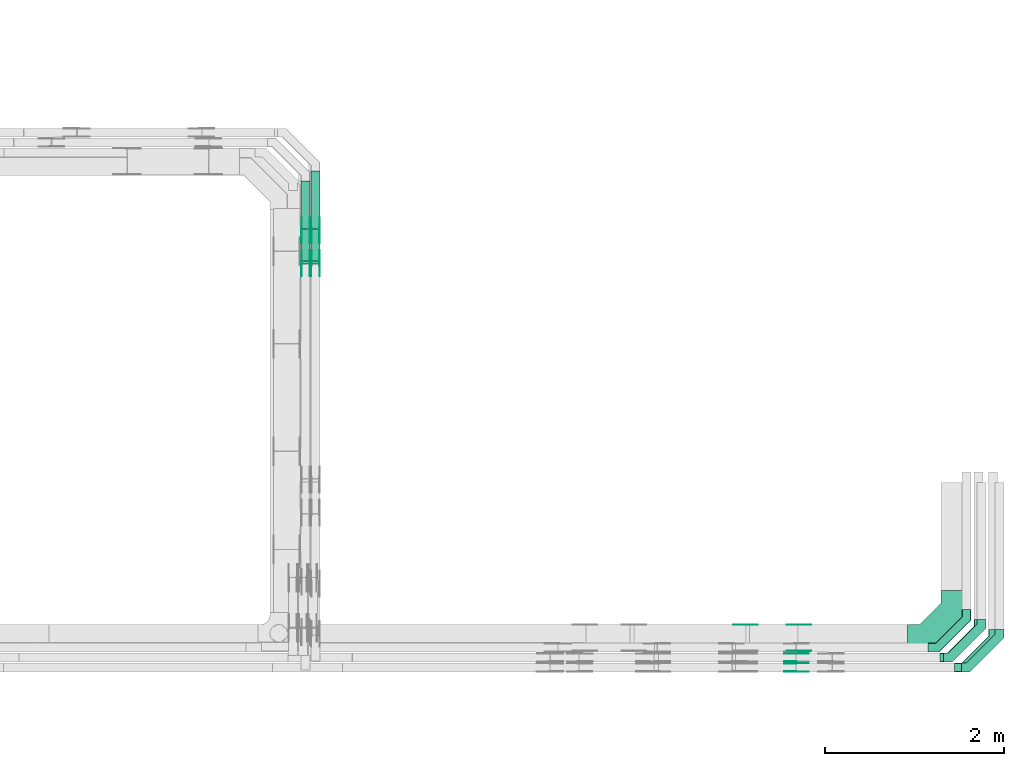
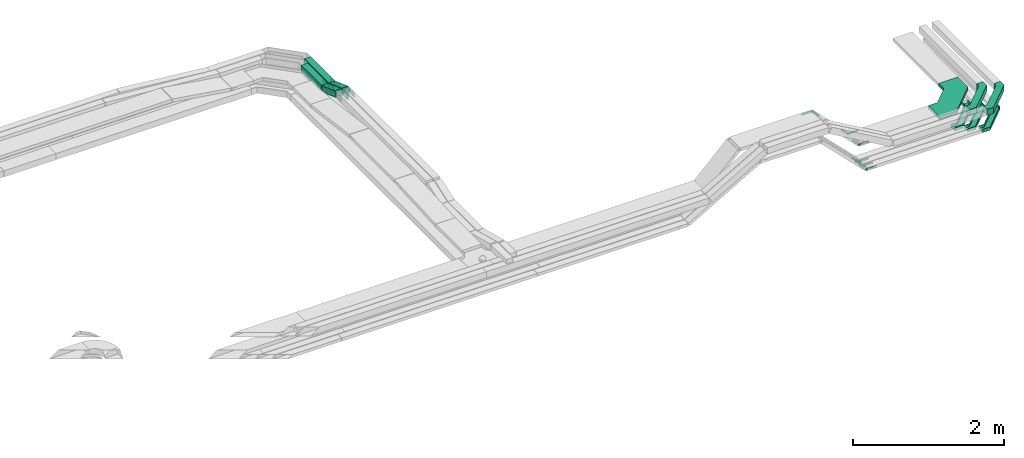
# One storey, part 27 of 33: 35 flow fittings, 4 flow segments.
"""IFC2X3 building model written with IfcOpenShell, lengths in millimetres."""

from ifc_helpers import new_model, entity, si_unit, converted_unit, derived_unit, direction, frame, frame_2d, origin, origin_2d_with_axis, place, context, subcontext, project, spatial, polyline, circle_curve, parameter, trimmed, segment, composite_curve, rectangle, outline, extrude, faceted_brep, source, transform, mapped, material, type_object, type_shapes, element, save


model = new_model("IFC2X3")

# Units and contexts
model_context = context("Model", 3, precision=0.01, world=origin(), true_north=direction((6.12303176911189e-17, 1.0)))
body_context = subcontext(model_context, "Body", "Model", "MODEL_VIEW")
ifc_project = project(units=[si_unit("LENGTHUNIT", "METRE", prefix="MILLI"), si_unit("AREAUNIT", "SQUARE_METRE"), si_unit("VOLUMEUNIT", "CUBIC_METRE"), converted_unit("PLANEANGLEUNIT", "DEGREE", entity("IfcRatioMeasure", 0.0174532925199433), si_unit("PLANEANGLEUNIT", "RADIAN"), dimensions=[0, 0, 0, 0, 0, 0, 0]), si_unit("MASSUNIT", "GRAM", prefix="KILO"), derived_unit("MASSDENSITYUNIT", [(si_unit("MASSUNIT", "GRAM", prefix="KILO"), 1), (si_unit("LENGTHUNIT", "METRE"), -3)]), derived_unit("MOMENTOFINERTIAUNIT", [(si_unit("LENGTHUNIT", "METRE"), 4)]), si_unit("TIMEUNIT", "SECOND"), si_unit("FREQUENCYUNIT", "HERTZ"), si_unit("THERMODYNAMICTEMPERATUREUNIT", "DEGREE_CELSIUS"), derived_unit("THERMALTRANSMITTANCEUNIT", [(si_unit("MASSUNIT", "GRAM", prefix="KILO"), 1), (si_unit("THERMODYNAMICTEMPERATUREUNIT", "KELVIN"), -1), (si_unit("TIMEUNIT", "SECOND"), -3)]), derived_unit("VOLUMETRICFLOWRATEUNIT", [(si_unit("LENGTHUNIT", "METRE"), 3), (si_unit("TIMEUNIT", "SECOND"), -1)]), derived_unit("MASSFLOWRATEUNIT", [(si_unit("MASSUNIT", "GRAM", prefix="KILO"), 1), (si_unit("TIMEUNIT", "SECOND"), -1)]), derived_unit("ROTATIONALFREQUENCYUNIT", [(si_unit("TIMEUNIT", "SECOND"), -1)]), si_unit("ELECTRICCURRENTUNIT", "AMPERE"), si_unit("ELECTRICVOLTAGEUNIT", "VOLT"), si_unit("POWERUNIT", "WATT"), si_unit("FORCEUNIT", "NEWTON", prefix="KILO"), si_unit("ILLUMINANCEUNIT", "LUX"), si_unit("LUMINOUSFLUXUNIT", "LUMEN"), si_unit("LUMINOUSINTENSITYUNIT", "CANDELA"), derived_unit("USERDEFINED", [(si_unit("MASSUNIT", "GRAM", prefix="KILO"), -1), (si_unit("LENGTHUNIT", "METRE"), -2), (si_unit("TIMEUNIT", "SECOND"), 3), (si_unit("LUMINOUSFLUXUNIT", "LUMEN"), 1)]), derived_unit("LINEARVELOCITYUNIT", [(si_unit("LENGTHUNIT", "METRE"), 1), (si_unit("TIMEUNIT", "SECOND"), -1)]), si_unit("PRESSUREUNIT", "PASCAL"), derived_unit("USERDEFINED", [(si_unit("LENGTHUNIT", "METRE"), -2), (si_unit("MASSUNIT", "GRAM", prefix="KILO"), 1), (si_unit("TIMEUNIT", "SECOND"), -2)]), derived_unit("LINEARFORCEUNIT", [(si_unit("MASSUNIT", "GRAM", prefix="KILO"), 1), (si_unit("LENGTHUNIT", "METRE"), 1), (si_unit("TIMEUNIT", "SECOND"), -2), (si_unit("LENGTHUNIT", "METRE"), -1)]), derived_unit("PLANARFORCEUNIT", [(si_unit("MASSUNIT", "GRAM", prefix="KILO"), 1), (si_unit("LENGTHUNIT", "METRE"), 1), (si_unit("TIMEUNIT", "SECOND"), -2), (si_unit("LENGTHUNIT", "METRE"), -2)])], contexts=[model_context])

# Site, building, storey
site_placement = place(None, frame((0.0, -0.00077364408347762, 0.0)))
site = spatial("IfcSite", under=ifc_project, at=site_placement, CompositionType="ELEMENT")
building_placement = place(site_placement, origin())
building = spatial("IfcBuilding", under=site, at=building_placement, CompositionType="ELEMENT")
storey_placement = place(building_placement, frame((0.0, 0.0, 8100.0)))
storey = spatial("IfcBuildingStorey", under=building, at=storey_placement, CompositionType="ELEMENT", Elevation=8100.0)

# Flow segments
cable_carrier_segment_type = type_object("IfcCableCarrierSegmentType", PredefinedType="CABLETRAYSEGMENT")
flow_segment_1_placement = place(storey_placement, frame((60610.1085349486, 13576.5618483229, 2715.06307654171)))
element("IfcFlowSegment", 1, at=flow_segment_1_placement, inside=storey, type_object=cable_carrier_segment_type, context=body_context, shape_type="SweptSolid", body=[
    extrude(rectangle(XDim=539.716387424886, YDim=99.9999999999946, at=origin_2d_with_axis()), frame((50.0, 269.858193712445, 0.0), z_axis=(0.0, 0.0, 1.0), x_axis=(0.0, 1.0, 0.0)), (0.0, 0.0, 1.0), 100.000000000001),
])
flow_segment_2_placement = place(storey_placement, frame((60720.1085349486, 13576.5636134989, 2715.06343817578)))
element("IfcFlowSegment", 2, at=flow_segment_2_placement, inside=storey, type_object=cable_carrier_segment_type, context=body_context, shape_type="SweptSolid", body=[
    extrude(rectangle(XDim=649.712946592026, YDim=99.9999999999946, at=frame_2d((-1.08002495835535e-12, -4.33075797445781e-12), x_axis=(1.0, 0.0))), frame((50.0, 324.859825636119, 0.0108908868867957), z_axis=(0.0, -3.35252266217634e-05, 1.0), x_axis=(0.0, 1.0, 3.35252266217634e-05)), (0.0, 0.0, 1.0), 99.9999999999995),
])
flow_segment_3_placement = place(storey_placement, frame((60610.1085349486, 13187.916855974, 2721.67706412331)))
element("IfcFlowSegment", 3, at=flow_segment_3_placement, inside=storey, type_object=cable_carrier_segment_type, context=body_context, shape_type="SweptSolid", body=[
    extrude(rectangle(XDim=99.9999999999998, YDim=99.9999999999946, at=frame_2d((0.0, -1.3926637620898e-12), x_axis=(0.0, 1.0))), frame((50.0, 17.1010071662862, 174.787393797573), z_axis=(0.0, 0.939692620785896, -0.342020143325703), x_axis=(-1.0, 0.0, 0.0)), (0.0, 0.0, 1.0), 373.670280105611),
])
flow_segment_4_placement = place(storey_placement, frame((60720.1085351478, 13187.9174212952, 2721.68065076364)))
element("IfcFlowSegment", 4, at=flow_segment_4_placement, inside=storey, type_object=cable_carrier_segment_type, context=body_context, shape_type="SweptSolid", body=[
    extrude(rectangle(XDim=99.9999996016359, YDim=99.9999996016381, at=frame_2d((0.0, -3.73034936274053e-13), x_axis=(0.0, 1.0))), frame((49.9999998008364, 17.1052008576487, 174.818569363195), z_axis=(0.0, 0.939662088474048, -0.342104018515701), x_axis=(-1.0, 0.0, 0.0)), (0.0, 0.0, 1.0), 373.674257558546),
])

# Flow fittings
ifc_material_1 = material()
cable_carrier_fitting_type_1 = type_object("IfcCableCarrierFittingType", Name="470_DKC_G5_Sheet horizontal bend:-", PredefinedType="NOTDEFINED", material=ifc_material_1)
shared_shape_1 = source(origin(), body_context, "Body", "SweptSolid", [
    extrude(outline(polyline([(-232.0, -244.0), (-135.289321881345, -244.0), (244.0, 135.289321881344), (244.0, 232.0), (144.0, 232.0), (144.0, 176.710678118654), (-176.710678118654, -144.0), (-232.0, -144.0), (-232.0, -244.0)])), frame((-194.0, 194.0, -50.0)), (0.0, 0.0, 1.0), 100.0),
])
type_shapes(cable_carrier_fitting_type_1, [shared_shape_1])
for number, where, name in (
    (5, (68397.1884624457, 8689.98005285082, 2792.0), "470_DKC_G5_Sheet horizontal bend:-"),
    (6, (68197.1884624458, 8799.97860618828, 2792.0), "470_DKC_G5_Sheet horizontal bend:-"),
):
    element("IfcFlowFitting", number, at=place(storey_placement, frame(where)), inside=storey, type_object=cable_carrier_fitting_type_1, material=ifc_material_1, Name=name, ObjectType="470_DKC_G5_Sheet horizontal bend:-", context=body_context, shape_type="MappedRepresentation", body=[
        mapped(shared_shape_1, transform((0.0, 0.0, 0.0), scale=1.0)),
    ])
cable_carrier_fitting_type_2 = type_object("IfcCableCarrierFittingType", Name="470_DKC_G5_Sheet horizontal bend:-", PredefinedType="NOTDEFINED", material=ifc_material_1)
shared_shape_2 = source(origin(), body_context, "Body", "SweptSolid", [
    extrude(outline(polyline([(-313.25, -362.749999999999), (-50.1179656440352, -362.749999999999), (362.749999999999, 50.1179656440355), (362.75, 313.249999999999), (62.7499999999997, 313.249999999999), (62.7499999999996, 174.382034355964), (-174.382034355964, -62.7499999999997), (-313.25, -62.7499999999996), (-313.25, -362.749999999999)])), frame((-212.749999999993, 212.749999999989, -25.0)), (0.0, 0.0, 1.0), 50.0000000000003),
])
type_shapes(cable_carrier_fitting_type_2, [shared_shape_2])
flow_fitting_placement = place(storey_placement, frame((67897.1884624458, 9019.97860618827, 2767.0)))
element("IfcFlowFitting", 7, at=flow_fitting_placement, inside=storey, type_object=cable_carrier_fitting_type_2, material=ifc_material_1, Name="470_DKC_G5_Sheet horizontal bend:-", ObjectType="470_DKC_G5_Sheet horizontal bend:-", context=body_context, shape_type="MappedRepresentation", body=[
    mapped(shared_shape_2, transform((0.0, 0.0, 0.0), scale=1.0)),
])
ifc_material_2 = material(Name="G")
cable_carrier_fitting_type_3 = type_object("IfcCableCarrierFittingType", PredefinedType="NOTDEFINED", material=ifc_material_2)
shared_shape_3 = source(origin(), body_context, "Body", "SweptSolid", [
    extrude(outline(composite_curve([segment(trimmed(circle_curve(frame_2d((-44.5901162790698, 0.0), x_axis=(1.0, 0.0)), 12.5), [parameter(90.0000000000007)], [parameter(270.0)], True, "PARAMETER"), True, "CONTINUOUS"), segment(polyline([(-44.5901162790697, -12.5), (-33.0901162790698, -12.5)]), True, "CONTINUOUS"), segment(polyline([(-33.0901162790698, -12.5), (-31.2296511627907, -14.5)]), True, "CONTINUOUS"), segment(polyline([(-31.2296511627907, -14.5), (108.90988372093, -14.5)]), True, "CONTINUOUS"), segment(polyline([(108.90988372093, -14.5), (108.90988372093, 14.5)]), True, "CONTINUOUS"), segment(polyline([(108.90988372093, 14.5), (-31.2296511627907, 14.5)]), True, "CONTINUOUS"), segment(polyline([(-31.2296511627907, 14.5), (-33.0901162790698, 12.5)]), True, "CONTINUOUS"), segment(polyline([(-33.0901162790698, 12.5), (-44.5901162790699, 12.5)]), True, "CONTINUOUS")], self_intersect=False)), frame((44.5901162790698, 0.0, 0.0), z_axis=(0.0, 0.0, -1.0), x_axis=(1.0, 0.0, 0.0)), (0.0, 0.0, -1.0), 2.0),
])
type_shapes(cable_carrier_fitting_type_3, [shared_shape_3])
for number, where, z_axis, x_axis in (
    (8, (65581.9936666899, 9165.43860619844, 3327.14825589831), (0.0, 1.0, 0.0), (0.707106781186591, 0.0, -0.707106781186504)),
    (9, (66118.4572387913, 8644.5200528406, 2514.200002718), (0.0, -1.0, 0.0), (1.0, 0.0, 0.0)),
    (10, (66142.1419225882, 8874.51860617812, 2767.0), (0.0, -1.0, 0.0), (1.0, 0.0, 0.0)),
):
    element("IfcFlowFitting", number, at=place(storey_placement, frame(where, z_axis=z_axis, x_axis=x_axis)), inside=storey, type_object=cable_carrier_fitting_type_3, material=ifc_material_2, context=body_context, shape_type="MappedRepresentation", body=[
        mapped(shared_shape_3, transform((0.0, 0.0, 0.0), scale=1.0)),
    ])
cable_carrier_fitting_type_4 = type_object("IfcCableCarrierFittingType", PredefinedType="NOTDEFINED", material=ifc_material_2)
shared_shape_4 = source(origin(), body_context, "Body", "SweptSolid", [
    extrude(outline(composite_curve([segment(trimmed(circle_curve(frame_2d((-44.5901162790697, 0.0), x_axis=(1.0, 0.0)), 12.5), [parameter(90.0000000000007)], [parameter(270.0)], True, "PARAMETER"), True, "CONTINUOUS"), segment(polyline([(-44.5901162790697, -12.5), (-33.0901162790697, -12.5)]), True, "CONTINUOUS"), segment(polyline([(-33.0901162790697, -12.5), (-31.2296511627907, -14.5)]), True, "CONTINUOUS"), segment(polyline([(-31.2296511627907, -14.5), (108.90988372093, -14.5)]), True, "CONTINUOUS"), segment(polyline([(108.90988372093, -14.5), (108.90988372093, 14.5)]), True, "CONTINUOUS"), segment(polyline([(108.90988372093, 14.5), (-31.2296511627907, 14.5)]), True, "CONTINUOUS"), segment(polyline([(-31.2296511627907, 14.5), (-33.0901162790698, 12.5)]), True, "CONTINUOUS"), segment(polyline([(-33.0901162790698, 12.5), (-44.5901162790699, 12.5)]), True, "CONTINUOUS")], self_intersect=False)), frame((44.5901162790697, 0.0, 0.0)), (0.0, 0.0, 1.0), 2.0),
])
type_shapes(cable_carrier_fitting_type_4, [shared_shape_4])
for number, where, z_axis, x_axis in (
    (11, (66118.4572387915, 8845.43860619836, 2514.20000271791), (0.0, 1.0, 0.0), (1.0, 0.0, 0.0)),
    (12, (66118.4572387913, 8735.44005286092, 2514.20000271799), (0.0, 1.0, 0.0), (1.0, 0.0, 0.0)),
    (13, (66142.1419225882, 9165.43860619843, 2767.0), (0.0, 1.0, 0.0), (1.0, 0.0, 0.0)),
):
    element("IfcFlowFitting", number, at=place(storey_placement, frame(where, z_axis=z_axis, x_axis=x_axis)), inside=storey, type_object=cable_carrier_fitting_type_4, material=ifc_material_2, context=body_context, shape_type="MappedRepresentation", body=[
        mapped(shared_shape_4, transform((0.0, 0.0, 0.0), scale=1.0)),
    ])
cable_carrier_fitting_type_5 = type_object("IfcCableCarrierFittingType", PredefinedType="NOTDEFINED", material=ifc_material_2)
shared_shape_5 = source(origin(), body_context, "Body", "SweptSolid", [
    extrude(outline(composite_curve([segment(trimmed(circle_curve(frame_2d((-44.5901162790698, 0.0), x_axis=(1.0, 0.0)), 12.5), [parameter(90.0000000000007)], [parameter(270.0)], True, "PARAMETER"), True, "CONTINUOUS"), segment(polyline([(-44.5901162790697, -12.5), (-33.0901162790698, -12.5)]), True, "CONTINUOUS"), segment(polyline([(-33.0901162790698, -12.5), (-31.2296511627907, -14.5)]), True, "CONTINUOUS"), segment(polyline([(-31.2296511627907, -14.5), (108.90988372093, -14.5)]), True, "CONTINUOUS"), segment(polyline([(108.90988372093, -14.5), (108.90988372093, 14.5)]), True, "CONTINUOUS"), segment(polyline([(108.90988372093, 14.5), (-31.2296511627907, 14.5)]), True, "CONTINUOUS"), segment(polyline([(-31.2296511627907, 14.5), (-33.0901162790698, 12.5)]), True, "CONTINUOUS"), segment(polyline([(-33.0901162790698, 12.5), (-44.5901162790699, 12.5)]), True, "CONTINUOUS")], self_intersect=False)), frame((44.5901162790698, 0.0, 0.0), z_axis=(0.0, 0.0, -1.0), x_axis=(1.0, 0.0, 0.0)), (0.0, 0.0, -1.0), 2.0),
])
type_shapes(cable_carrier_fitting_type_5, [shared_shape_5])
for number, where, z_axis, x_axis in (
    (14, (66118.4572387915, 8843.43860619836, 2514.20000271791), (0.0, 1.0, 0.0), (-0.707106781186549, 0.0, 0.707106781186547)),
    (15, (66118.4572387913, 8733.44005286092, 2514.20000271799), (0.0, 1.0, 0.0), (-0.707106781186497, 0.0, 0.707106781186598)),
    (16, (66142.1419225882, 9163.43860619843, 2767.0), (0.0, 1.0, 0.0), (-0.707106781186539, 0.0, 0.707106781186556)),
):
    element("IfcFlowFitting", number, at=place(storey_placement, frame(where, z_axis=z_axis, x_axis=x_axis)), inside=storey, type_object=cable_carrier_fitting_type_5, material=ifc_material_2, context=body_context, shape_type="MappedRepresentation", body=[
        mapped(shared_shape_5, transform((0.0, 0.0, 0.0), scale=1.0)),
    ])
cable_carrier_fitting_type_6 = type_object("IfcCableCarrierFittingType", PredefinedType="NOTDEFINED", material=ifc_material_2)
shared_shape_6 = source(origin(), body_context, "Body", "SweptSolid", [
    extrude(outline(composite_curve([segment(trimmed(circle_curve(frame_2d((-44.5901162790697, 0.0), x_axis=(1.0, 0.0)), 12.5), [parameter(90.0000000000007)], [parameter(270.0)], True, "PARAMETER"), True, "CONTINUOUS"), segment(polyline([(-44.5901162790697, -12.5), (-33.0901162790697, -12.5)]), True, "CONTINUOUS"), segment(polyline([(-33.0901162790697, -12.5), (-31.2296511627907, -14.5)]), True, "CONTINUOUS"), segment(polyline([(-31.2296511627907, -14.5), (108.90988372093, -14.5)]), True, "CONTINUOUS"), segment(polyline([(108.90988372093, -14.5), (108.90988372093, 14.5)]), True, "CONTINUOUS"), segment(polyline([(108.90988372093, 14.5), (-31.2296511627907, 14.5)]), True, "CONTINUOUS"), segment(polyline([(-31.2296511627907, 14.5), (-33.0901162790698, 12.5)]), True, "CONTINUOUS"), segment(polyline([(-33.0901162790698, 12.5), (-44.5901162790699, 12.5)]), True, "CONTINUOUS")], self_intersect=False)), frame((44.5901162790697, 0.0, 0.0)), (0.0, 0.0, 1.0), 2.0),
])
type_shapes(cable_carrier_fitting_type_6, [shared_shape_6])
for number, where, z_axis, x_axis in (
    (17, (65581.9936666899, 9163.43860619843, 3327.14825589831), (0.0, 1.0, 0.0), (-1.0, 0.0, 0.0)),
    (18, (66118.4572387915, 8756.51860617805, 2514.20000271791), (0.0, -1.0, 0.0), (-0.707106781186549, 0.0, 0.707106781186547)),
    (19, (66118.4572387913, 8646.5200528406, 2514.200002718), (0.0, -1.0, 0.0), (-0.707106781186497, 0.0, 0.707106781186598)),
    (20, (66142.1419225882, 8876.51860617812, 2767.0), (0.0, -1.0, 0.0), (-0.707106781186539, 0.0, 0.707106781186556)),
):
    element("IfcFlowFitting", number, at=place(storey_placement, frame(where, z_axis=z_axis, x_axis=x_axis)), inside=storey, type_object=cable_carrier_fitting_type_6, material=ifc_material_2, context=body_context, shape_type="MappedRepresentation", body=[
        mapped(shared_shape_6, transform((0.0, 0.0, 0.0), scale=1.0)),
    ])
cable_carrier_fitting_type_7 = type_object("IfcCableCarrierFittingType", PredefinedType="NOTDEFINED", material=ifc_material_2)
shared_shape_7 = source(origin(), body_context, "Body", "SweptSolid", [
    extrude(outline(composite_curve([segment(trimmed(circle_curve(frame_2d((-41.4651162790697, 0.0), x_axis=(1.0, 0.0)), 25.0), [parameter(90.0000000000007)], [parameter(270.0)], True, "PARAMETER"), True, "CONTINUOUS"), segment(polyline([(-41.4651162790697, -25.0), (-29.9651162790697, -25.0)]), True, "CONTINUOUS"), segment(polyline([(-29.9651162790697, -25.0), (-28.1046511627907, -38.5)]), True, "CONTINUOUS"), segment(polyline([(-28.1046511627907, -38.5), (99.5348837209303, -38.5)]), True, "CONTINUOUS"), segment(polyline([(99.5348837209303, -38.5), (99.5348837209303, 38.5)]), True, "CONTINUOUS"), segment(polyline([(99.5348837209303, 38.5), (-28.1046511627907, 38.5)]), True, "CONTINUOUS"), segment(polyline([(-28.1046511627907, 38.5), (-29.9651162790697, 25.0)]), True, "CONTINUOUS"), segment(polyline([(-29.9651162790697, 25.0), (-41.46511627907, 25.0)]), True, "CONTINUOUS")], self_intersect=False)), frame((41.4651162790697, 0.0, 0.0), z_axis=(0.0, 0.0, -1.0), x_axis=(1.0, 0.0, 0.0)), (0.0, 0.0, -1.0), 2.0),
])
type_shapes(cable_carrier_fitting_type_7, [shared_shape_7])
for number, where, z_axis, x_axis in (
    (21, (60614.6485349384, 13566.0401913646, 2765.06307654169), (-1.0, 0.0, 0.0), (0.0, -0.939692620785909, 0.342020143325668)),
    (22, (60705.5685349588, 13195.1307397382, 2900.06307654179), (1.0, 0.0, 0.0), (0.0, -1.0, 0.0)),
    (23, (60815.5685349588, 13566.0401913648, 2765.06307654168), (1.0, 0.0, 0.0), (0.0, 1.0, 3.43565421406233e-05)),
    (24, (60815.5685349588, 13195.1334849806, 2900.09957136776), (1.0, 0.0, 0.0), (0.0, -1.0, 0.0)),
):
    element("IfcFlowFitting", number, at=place(storey_placement, frame(where, z_axis=z_axis, x_axis=x_axis)), inside=storey, type_object=cable_carrier_fitting_type_7, material=ifc_material_2, context=body_context, shape_type="MappedRepresentation", body=[
        mapped(shared_shape_7, transform((0.0, 0.0, 0.0), scale=1.0)),
    ])
cable_carrier_fitting_type_8 = type_object("IfcCableCarrierFittingType", PredefinedType="NOTDEFINED", material=ifc_material_2)
shared_shape_8 = source(origin(), body_context, "Body", "SweptSolid", [
    extrude(outline(composite_curve([segment(trimmed(circle_curve(frame_2d((-41.4651162790697, 0.0), x_axis=(1.0, 0.0)), 25.0), [parameter(90.0000000000007)], [parameter(270.0)], True, "PARAMETER"), True, "CONTINUOUS"), segment(polyline([(-41.4651162790697, -25.0), (-29.9651162790697, -25.0)]), True, "CONTINUOUS"), segment(polyline([(-29.9651162790697, -25.0), (-28.1046511627907, -38.5)]), True, "CONTINUOUS"), segment(polyline([(-28.1046511627907, -38.5), (99.5348837209303, -38.5)]), True, "CONTINUOUS"), segment(polyline([(99.5348837209303, -38.5), (99.5348837209303, 38.5)]), True, "CONTINUOUS"), segment(polyline([(99.5348837209303, 38.5), (-28.1046511627907, 38.5)]), True, "CONTINUOUS"), segment(polyline([(-28.1046511627907, 38.5), (-29.9651162790697, 25.0)]), True, "CONTINUOUS"), segment(polyline([(-29.9651162790697, 25.0), (-41.46511627907, 25.0)]), True, "CONTINUOUS")], self_intersect=False)), frame((41.4651162790697, 0.0, 0.0)), (0.0, 0.0, 1.0), 2.0),
])
type_shapes(cable_carrier_fitting_type_8, [shared_shape_8])
for number, where, z_axis, x_axis in (
    (25, (60705.5685349588, 13566.0401913646, 2765.06307654169), (1.0, 0.0, 0.0), (0.0, -0.939692620785909, 0.342020143325668)),
    (26, (60614.6485349384, 13195.1307397382, 2900.06307654179), (-1.0, 0.0, 0.0), (0.0, -1.0, 0.0)),
    (27, (60724.6485349384, 13566.0401913648, 2765.06307654168), (-1.0, 0.0, 0.0), (0.0, 1.0, 3.43565421406233e-05)),
    (28, (60724.6485349384, 13195.1334849806, 2900.09957136777), (-1.0, 0.0, 0.0), (0.0, -1.0, 0.0)),
):
    element("IfcFlowFitting", number, at=place(storey_placement, frame(where, z_axis=z_axis, x_axis=x_axis)), inside=storey, type_object=cable_carrier_fitting_type_8, material=ifc_material_2, context=body_context, shape_type="MappedRepresentation", body=[
        mapped(shared_shape_8, transform((0.0, 0.0, 0.0), scale=1.0)),
    ])
cable_carrier_fitting_type_9 = type_object("IfcCableCarrierFittingType", PredefinedType="NOTDEFINED", material=ifc_material_2)
shared_shape_9 = source(origin(), body_context, "Body", "SweptSolid", [
    extrude(outline(composite_curve([segment(trimmed(circle_curve(frame_2d((-41.4651162790697, 0.0), x_axis=(1.0, 0.0)), 25.0), [parameter(90.0000000000007)], [parameter(270.0)], True, "PARAMETER"), True, "CONTINUOUS"), segment(polyline([(-41.4651162790697, -25.0), (-29.9651162790697, -25.0)]), True, "CONTINUOUS"), segment(polyline([(-29.9651162790697, -25.0), (-28.1046511627907, -38.5)]), True, "CONTINUOUS"), segment(polyline([(-28.1046511627907, -38.5), (99.5348837209303, -38.5)]), True, "CONTINUOUS"), segment(polyline([(99.5348837209303, -38.5), (99.5348837209303, 38.5)]), True, "CONTINUOUS"), segment(polyline([(99.5348837209303, 38.5), (-28.1046511627907, 38.5)]), True, "CONTINUOUS"), segment(polyline([(-28.1046511627907, 38.5), (-29.9651162790697, 25.0)]), True, "CONTINUOUS"), segment(polyline([(-29.9651162790697, 25.0), (-41.46511627907, 25.0)]), True, "CONTINUOUS")], self_intersect=False)), frame((41.4651162790697, 0.0, 0.0), z_axis=(0.0, 0.0, -1.0), x_axis=(1.0, 0.0, 0.0)), (0.0, 0.0, -1.0), 2.0),
])
type_shapes(cable_carrier_fitting_type_9, [shared_shape_9])
for number, where, z_axis, x_axis in (
    (29, (60703.5685349588, 13566.0401913646, 2765.0630765417), (1.0, 0.0, 0.0), (0.0, 1.0, 0.0)),
    (30, (60616.6485349384, 13195.1307397382, 2900.06307654179), (-1.0, 0.0, 0.0), (0.0, 0.939692620785898, -0.342020143325699)),
    (31, (60726.6485349384, 13566.0401913648, 2765.06307654168), (-1.0, 0.0, 0.0), (0.0, -0.939662088474059, 0.34210401851567)),
    (32, (60726.6485349384, 13195.1334849805, 2900.09957136776), (-1.0, 0.0, 0.0), (0.0, 0.939662088474052, -0.342104018515689)),
):
    element("IfcFlowFitting", number, at=place(storey_placement, frame(where, z_axis=z_axis, x_axis=x_axis)), inside=storey, type_object=cable_carrier_fitting_type_9, material=ifc_material_2, context=body_context, shape_type="MappedRepresentation", body=[
        mapped(shared_shape_9, transform((0.0, 0.0, 0.0), scale=1.0)),
    ])
cable_carrier_fitting_type_10 = type_object("IfcCableCarrierFittingType", PredefinedType="NOTDEFINED", material=ifc_material_2)
shared_shape_10 = source(origin(), body_context, "Body", "SweptSolid", [
    extrude(outline(composite_curve([segment(trimmed(circle_curve(frame_2d((-41.4651162790697, 0.0), x_axis=(1.0, 0.0)), 25.0), [parameter(90.0000000000007)], [parameter(270.0)], True, "PARAMETER"), True, "CONTINUOUS"), segment(polyline([(-41.4651162790697, -25.0), (-29.9651162790697, -25.0)]), True, "CONTINUOUS"), segment(polyline([(-29.9651162790697, -25.0), (-28.1046511627907, -38.5)]), True, "CONTINUOUS"), segment(polyline([(-28.1046511627907, -38.5), (99.5348837209303, -38.5)]), True, "CONTINUOUS"), segment(polyline([(99.5348837209303, -38.5), (99.5348837209303, 38.5)]), True, "CONTINUOUS"), segment(polyline([(99.5348837209303, 38.5), (-28.1046511627907, 38.5)]), True, "CONTINUOUS"), segment(polyline([(-28.1046511627907, 38.5), (-29.9651162790697, 25.0)]), True, "CONTINUOUS"), segment(polyline([(-29.9651162790697, 25.0), (-41.46511627907, 25.0)]), True, "CONTINUOUS")], self_intersect=False)), frame((41.4651162790697, 0.0, 0.0)), (0.0, 0.0, 1.0), 2.0),
])
type_shapes(cable_carrier_fitting_type_10, [shared_shape_10])
for number, where, z_axis, x_axis in (
    (33, (60616.6485349384, 13566.0401913646, 2765.0630765417), (-1.0, 0.0, 0.0), (0.0, 1.0, 0.0)),
    (34, (60703.5685349587, 13195.1307397382, 2900.06307654178), (1.0, 0.0, 0.0), (0.0, 0.939692620785898, -0.342020143325699)),
    (35, (60813.5685349587, 13566.0401913648, 2765.06307654168), (1.0, 0.0, 0.0), (0.0, -0.939662088474059, 0.34210401851567)),
    (36, (60813.5685349588, 13195.1334849805, 2900.09957136776), (1.0, 0.0, 0.0), (0.0, 0.939662088474052, -0.342104018515689)),
):
    element("IfcFlowFitting", number, at=place(storey_placement, frame(where, z_axis=z_axis, x_axis=x_axis)), inside=storey, type_object=cable_carrier_fitting_type_10, material=ifc_material_2, context=body_context, shape_type="MappedRepresentation", body=[
        mapped(shared_shape_10, transform((0.0, 0.0, 0.0), scale=1.0)),
    ])
cable_carrier_fitting_type_11 = type_object("IfcCableCarrierFittingType", Name="470_DKC_G5_Sheet horizontal bend:-", PredefinedType="NOTDEFINED", material=ifc_material_1)
shared_shape_11 = source(origin(), body_context, "Body", "Brep", [
    faceted_brep([(-426.0, -50.0, -25.0), (-426.0, -50.0, 25.0), (-426.0, -45.0, 25.0), (-426.0, -45.0, -20.0), (-426.0, 45.0, -20.0), (-426.0, 45.0, 25.0), (-426.0, 50.0, 25.0), (-426.0, 50.0, -25.0), (50.0, 426.0, -25.0), (-50.0, 426.0, -25.0), (-50.0, 426.0, 25.0), (-45.0, 426.0, 25.0), (-45.0, 426.0, -20.0), (45.0, 426.0, -20.0), (45.0, 426.0, 25.0), (50.0, 426.0, 25.0), (-304.289321881337, -50.0, -25.0), (-304.289321881337, -50.0, 25.0), (50.0, 304.289321881334, 25.0), (45.0, 306.3603896932, 25.0), (-306.360389693203, -45.0, 25.0), (-306.360389693203, -45.0, -20.0), (45.0, 306.3603896932, -20.0), (-45.0, 343.639610306778, -20.0), (-343.639610306781, 45.0, -20.0), (-343.639610306781, 45.0, 25.0), (-45.0, 343.639610306778, 25.0), (-50.0, 345.710678118644, 25.0), (-345.710678118647, 50.0, 25.0), (-345.710678118647, 50.0, -25.0), (-50.0, 345.710678118644, -25.0), (50.0, 304.289321881334, -25.0)], [[[0, 1, 2, 3, 4, 5, 6, 7]], [[8, 9, 10, 11, 12, 13, 14, 15]], [[1, 0, 16, 17]], [[2, 1, 17, 18, 15, 14, 19, 20]], [[3, 2, 20, 21]], [[4, 3, 21, 22, 13, 12, 23, 24]], [[5, 4, 24, 25]], [[6, 5, 25, 26, 11, 10, 27, 28]], [[7, 6, 28, 29]], [[0, 7, 29, 30, 9, 8, 31, 16]], [[17, 16, 31, 18]], [[21, 20, 19, 22]], [[25, 24, 23, 26]], [[29, 28, 27, 30]], [[18, 31, 8, 15]], [[22, 19, 14, 13]], [[26, 23, 12, 11]], [[30, 27, 10, 9]]]),
])
type_shapes(cable_carrier_fitting_type_11, [shared_shape_11])
for number, where, name in (
    (37, (68027.7090440674, 8909.97860618819, 2514.20000271794), "470_DKC_G5_Sheet horizontal bend:-"),
    (38, (68161.5086960473, 8799.9786061882, 2514.20000271794), "470_DKC_G5_Sheet horizontal bend:-"),
    (39, (68323.1027300728, 8689.98005285073, 2514.20000271794), "470_DKC_G5_Sheet horizontal bend:-"),
):
    element("IfcFlowFitting", number, at=place(storey_placement, frame(where)), inside=storey, type_object=cable_carrier_fitting_type_11, material=ifc_material_1, Name=name, ObjectType="470_DKC_G5_Sheet horizontal bend:-", context=body_context, shape_type="MappedRepresentation", body=[
        mapped(shared_shape_11, transform((0.0, 0.0, 0.0), scale=1.0)),
    ])

save(model, "model.ifc")
